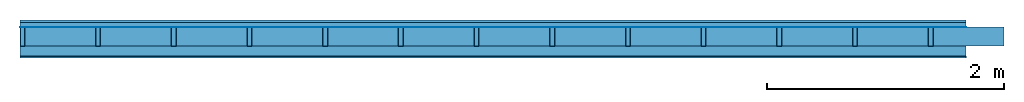
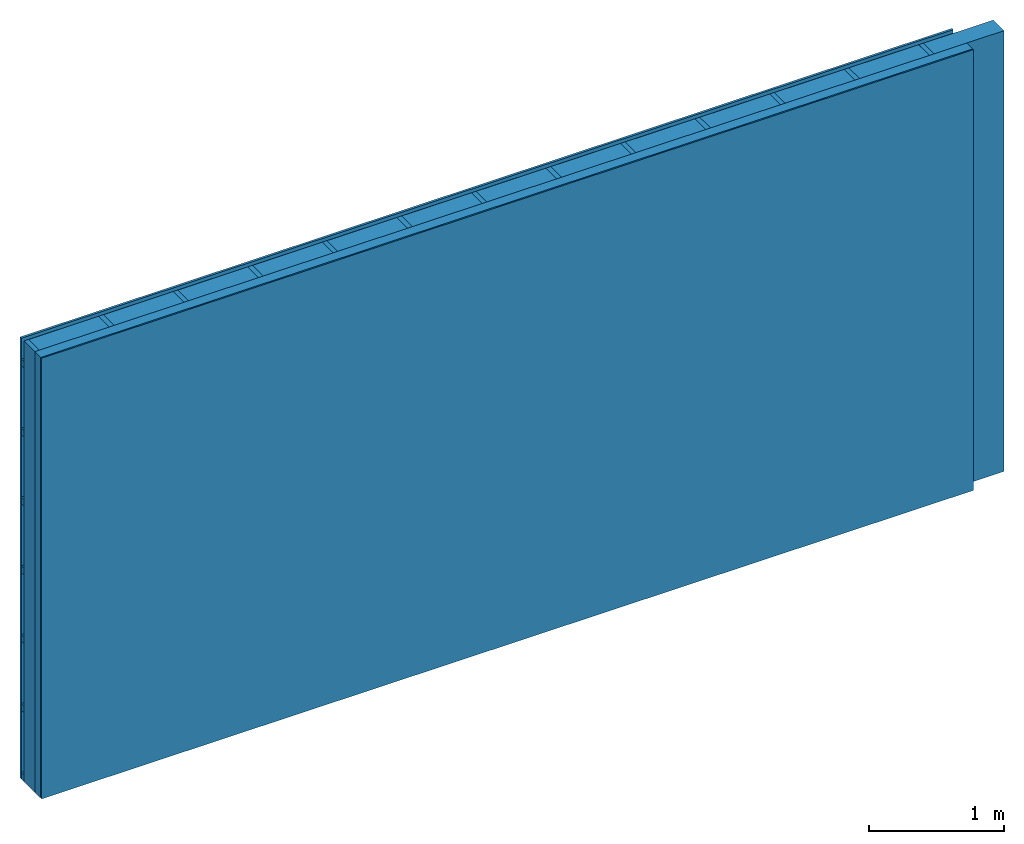
# One storey: 4 plates, 3 members, 1 element without a shape of its own.
"""IFC4 building model written with IfcOpenShell, lengths in metres."""

import ifcopenshell
import ifcopenshell.guid

model = None  # the IFC model being written
_history = None  # IfcOwnerHistory: only IFC2X3 demands one
_inside = {}  # id of a spatial element -> (the spatial element, [elements in it])
_under = {}  # id of a project, library or spatial element -> (it, [spatial elements below it])
_declared = {}  # id of a project -> (the project, [libraries it declares])
_typed = {}  # id of a type object -> (the type object, [elements of that type])
_made_of = {}  # id of a material, layer set ... -> (it, [elements and type objects made of it])


def new_model(schema):
    """Start an empty IFC model of exactly this schema.

    Asked for "IFC4X3", IfcOpenShell would pick the latest addendum, in which some entities
    have other attributes; the version numbers below select the first issue.
    IFC2X3 requires an IfcOwnerHistory on every rooted entity: one is made here for all.
    """
    global model, _history
    if schema == "IFC4X3":
        model = ifcopenshell.file(schema_version=(4, 3, 0, 0))
    else:
        model = ifcopenshell.file(schema=schema)
    _inside.clear()
    _under.clear()
    _declared.clear()
    _typed.clear()
    _made_of.clear()
    _history = None
    if model.schema == "IFC2X3":
        org = make("IfcOrganization", Name="unknown")
        user = make(
            "IfcPersonAndOrganization",
            ThePerson=make("IfcPerson", FamilyName="unknown"),
            TheOrganization=org,
        )
        app = make(
            "IfcApplication",
            ApplicationDeveloper=org,
            Version="unknown",
            ApplicationFullName="unknown",
            ApplicationIdentifier="unknown",
        )
        _history = make(
            "IfcOwnerHistory",
            OwningUser=user,
            OwningApplication=app,
            ChangeAction="ADDED",
            CreationDate=0,
        )
    return model


def make(cls, **values):
    """One entity of the class cls with the attributes given. An attribute that is None is left unset."""
    return model.create_entity(
        cls, **{name: value for name, value in values.items() if value is not None}
    )


def rooted(cls, **values):
    """An entity with a GlobalId (a new one), such as an element, a storey or a relation."""
    return make(cls, GlobalId=ifcopenshell.guid.new(), OwnerHistory=_history, **values)


def si_unit(unit_type, name, prefix=None):
    """IfcSIUnit, for example si_unit("LENGTHUNIT", "METRE", prefix="MILLI")."""
    return make("IfcSIUnit", UnitType=unit_type, Prefix=prefix, Name=name)


def derived_unit(unit_type, elements):
    """IfcDerivedUnit: a product of units, each with its exponent."""
    return make(
        "IfcDerivedUnit",
        Elements=[
            make("IfcDerivedUnitElement", Unit=unit, Exponent=power)
            for unit, power in elements
        ],
        UnitType=unit_type,
    )


def assignment(units):
    """IfcUnitAssignment: the units of a project."""
    return None if units is None else make("IfcUnitAssignment", Units=units)


def point(xyz):
    """IfcCartesianPoint."""
    return None if xyz is None else make("IfcCartesianPoint", Coordinates=xyz)


def direction(xyz):
    """IfcDirection."""
    return None if xyz is None else make("IfcDirection", DirectionRatios=xyz)


def frame(location, z_axis=None, x_axis=None):
    """IfcAxis2Placement3D, a coordinate frame: its origin and axes. An axis left out is left unset."""
    return make(
        "IfcAxis2Placement3D",
        Location=point(location),
        Axis=direction(z_axis),
        RefDirection=direction(x_axis),
    )


def frame_2d(location, x_axis=None):
    """IfcAxis2Placement2D, a coordinate frame in the plane: its origin and x axis."""
    return make(
        "IfcAxis2Placement2D", Location=point(location), RefDirection=direction(x_axis)
    )


def origin():
    """The frame at (0, 0, 0) with its axes left unset."""
    return frame((0.0, 0.0, 0.0))


def origin_with_axes():
    """The frame at (0, 0, 0) with the z axis (0, 0, 1) and the x axis (1, 0, 0) written out."""
    return frame((0.0, 0.0, 0.0), z_axis=(0.0, 0.0, 1.0), x_axis=(1.0, 0.0, 0.0))


def place(relative_to, where):
    """IfcLocalPlacement: puts the frame where relative to a parent placement (None: the world)."""
    return make(
        "IfcLocalPlacement", PlacementRelTo=relative_to, RelativePlacement=where
    )


def context(
    kind, dimensions, precision=None, world=None, true_north=None, identifier=None
):
    """IfcGeometricRepresentationContext, for example the 3D "Model" context."""
    return make(
        "IfcGeometricRepresentationContext",
        ContextIdentifier=identifier,
        ContextType=kind,
        CoordinateSpaceDimension=dimensions,
        Precision=precision,
        WorldCoordinateSystem=world,
        TrueNorth=true_north,
    )


def project(units=None, contexts=None):
    """IfcProject with its units and contexts."""
    return rooted(
        "IfcProject",
        Name="project",
        RepresentationContexts=contexts,
        UnitsInContext=assignment(units),
    )


def spatial(cls, under=None, at=None, **own):
    """A site, building, storey or space (cls), placed at a placement, below another one or the project."""
    s = rooted(cls, ObjectPlacement=at, **own)
    if under is not None:
        _under.setdefault(under.id(), (under, []))[1].append(s)
    return s


def profile(cls, at=None, kind="AREA", **sizes):
    """A parametric profile (cls). Its sizes go by their IFC names, for example OverallWidth=200.0."""
    return make(cls, ProfileType=kind, Position=at, **sizes)


def rectangle(**sizes):
    """IfcRectangleProfileDef."""
    return profile("IfcRectangleProfileDef", **sizes)


def extrude(swept, where, along, depth):
    """IfcExtrudedAreaSolid: the profile swept, set in the frame where, extruded along a direction by depth."""
    return make(
        "IfcExtrudedAreaSolid",
        SweptArea=swept,
        Position=where,
        ExtrudedDirection=direction(along),
        Depth=depth,
    )


def shape(context_of_items, identifier, shape_type, items):
    """IfcShapeRepresentation: the items that make up one representation, for example the "Body"."""
    return make(
        "IfcShapeRepresentation",
        ContextOfItems=context_of_items,
        RepresentationIdentifier=identifier,
        RepresentationType=shape_type,
        Items=items,
    )


def material(Name=None, Category=None):
    """IfcMaterial."""
    return make("IfcMaterial", Name=Name, Category=Category)


def layer(
    of_material, thickness, ventilated=None, Name=None, Category=None, Priority=None
):
    """IfcMaterialLayer: one layer of a wall or slab, of a material (None: an air gap)."""
    return make(
        "IfcMaterialLayer",
        Material=of_material,
        LayerThickness=thickness,
        IsVentilated=ventilated,
        Name=Name,
        Category=Category,
        Priority=Priority,
    )


def layer_set(layers, Name=None):
    """IfcMaterialLayerSet."""
    return make("IfcMaterialLayerSet", MaterialLayers=layers, LayerSetName=Name)


def made_of(thing, what):
    """Note that an element or type object is made of a material, layer set ...; save() writes the relation."""
    if what is not None:
        _made_of.setdefault(what.id(), (what, []))[1].append(thing)
    return thing


def type_object(cls, material=None, **own):
    """A type object (cls), such as IfcWallType, which elements share."""
    return made_of(rooted(cls, **own), material)


def element(
    cls,
    number,
    at=None,
    inside=None,
    cuts=None,
    type_object=None,
    material=None,
    context=None,
    identifier="Body",
    shape_type=None,
    held_by="IfcProductDefinitionShape",
    body=None,
    shapes=None,
    **own,
):
    """One element of the class cls, such as IfcWall. Its Tag is "e" and its number.

    at: its placement. inside: the storey or other place that contains it. cuts: it is an
    opening in that element (IfcRelVoidsElement). A single representation is given by context,
    identifier, shape_type and body (its items); several are given by shapes. held_by: the class
    of the entity that holds the representations. save() writes the other relations.
    """
    e = rooted(cls, Tag="e%d" % number, ObjectPlacement=at, **own)
    if body is not None:
        shapes = [shape(context, identifier, shape_type, body)]
    if shapes is not None:
        e.Representation = make(held_by, Representations=shapes)
    if inside is not None:
        _inside.setdefault(inside.id(), (inside, []))[1].append(e)
    if cuts is not None:
        rooted(
            "IfcRelVoidsElement", RelatingBuildingElement=cuts, RelatedOpeningElement=e
        )
    if type_object is not None:
        _typed.setdefault(type_object.id(), (type_object, []))[1].append(e)
    return made_of(e, material)


def aggregate(whole, parts):
    """IfcRelAggregates: a whole, such as a stair, and the parts it consists of."""
    return rooted("IfcRelAggregates", RelatingObject=whole, RelatedObjects=parts)


def save(model, path):
    """Write the relations noted so far, then the file.

    IfcRelAggregates (storeys below a building ...), IfcRelContainedInSpatialStructure (elements
    in a storey), IfcRelDefinesByType, IfcRelAssociatesMaterial and IfcRelDeclares: one each for
    every whole, place, type object, material and project.
    """
    for whole, parts in _under.values():
        aggregate(whole, parts)
    for where, things in _inside.values():
        rooted(
            "IfcRelContainedInSpatialStructure",
            RelatedElements=things,
            RelatingStructure=where,
        )
    for kind, things in _typed.values():
        rooted("IfcRelDefinesByType", RelatedObjects=things, RelatingType=kind)
    for what, things in _made_of.values():
        rooted("IfcRelAssociatesMaterial", RelatedObjects=things, RelatingMaterial=what)
    for by, libraries in _declared.values():
        rooted("IfcRelDeclares", RelatingContext=by, RelatedDefinitions=libraries)
    model.write(path)


model = new_model("IFC4")

# Units and contexts
plan_context = context("Plan", 3, precision=1e-05, world=origin(), true_north=direction((0.0, 1.0)))
model_context = context("Model", 3, precision=1e-05, world=origin(), true_north=direction((0.0, 1.0)))
ifc_project = project(units=[si_unit("LENGTHUNIT", "METRE"), derived_unit("SOUNDPRESSUREUNIT", [(si_unit("PRESSUREUNIT", "PASCAL", prefix="MICRO"), 0)]), si_unit("ENERGYUNIT", "JOULE", prefix="MEGA"), si_unit("MASSUNIT", "GRAM", prefix="KILO"), derived_unit("THERMALTRANSMITTANCEUNIT", [(si_unit("POWERUNIT", "WATT"), 1), (si_unit("AREAUNIT", "SQUARE_METRE"), -1), (si_unit("THERMODYNAMICTEMPERATUREUNIT", "KELVIN"), -1)]), derived_unit("AREADENSITYUNIT", [(si_unit("MASSUNIT", "GRAM", prefix="KILO"), 1), (si_unit("AREAUNIT", "SQUARE_METRE"), -1)]), derived_unit("USERDEFINED", [(si_unit("ENERGYUNIT", "JOULE", prefix="MEGA"), 1), (si_unit("AREAUNIT", "SQUARE_METRE"), -1)])], contexts=[plan_context, model_context])

# Site, building, storey
site = spatial("IfcSite", under=ifc_project)
building_placement = place(None, origin())
building = spatial("IfcBuilding", under=site, at=building_placement)
storey_placement = place(building_placement, origin())
storey = spatial("IfcBuildingStorey", under=building, at=storey_placement)

# Wall, members, plates
ifc_material_1 = material(Name="Wood cladding horizontal, closed")
ifc_layer_1 = layer(ifc_material_1, 0.02, Name="Cover 1st layer")
ifc_layer_2 = layer(None, 0.04, Name="Battens / profiles (ventilation)")
ifc_material_2 = material(Name="Vapor-permeable water barrier", Category="09.006")
ifc_layer_3 = layer(ifc_material_2, 0.0005, Name="outside 1st layer")
ifc_material_3 = material(Name="of the art")
ifc_layer_4 = layer(ifc_material_3, 0.0, Name="Bond")
ifc_layer_5 = layer(None, 0.16, Name="Support")
ifc_layer_6 = layer(ifc_material_3, 0.0, Name="Bond")
ifc_material_4 = material(Name="Solid timber panel")
ifc_layer_7 = layer(ifc_material_4, 0.087, Name="1st layer")
ifc_material_5 = material(Name="Plasterboard type A", Category="03.008")
ifc_layer_8 = layer(ifc_material_5, 0.0125, Name="Covering 1st layer")
ifc_material_6 = material(Name="joints", Category="04.017")
ifc_layer_9 = layer(ifc_material_6, 0.0, Name="Surface")
ifc_layer_set = layer_set([ifc_layer_1, ifc_layer_2, ifc_layer_3, ifc_layer_4, ifc_layer_5, ifc_layer_6, ifc_layer_7, ifc_layer_8, ifc_layer_9])
wall_type = type_object("IfcWallType", Name="D0984", PredefinedType="NOTDEFINED", material=ifc_layer_set)
wall_placement = place(None, frame((0.0, 0.0, 0.0), z_axis=(0.0, -1.0, 0.0), x_axis=(1.0, 0.0, 0.0)))
wall = element("IfcWall", 1, at=wall_placement, inside=storey, type_object=wall_type, material=ifc_layer_set, Name="Wall #1")
ifc_material_7 = material()
member_1_placement = place(wall_placement, origin())
member_1 = element("IfcMember", 2, at=member_1_placement, material=ifc_material_7, Name="Battens / profiles (ventilation)", context=plan_context, shape_type="SweptSolid", body=[
    extrude(rectangle(XDim=0.06, YDim=0.04, at=frame_2d((0.03, 0.02), x_axis=(1.0, 0.0))), frame((0.0, 0.0, 0.02), z_axis=(1.0, 0.0, 0.0), x_axis=(0.0, 1.0, 0.0)), (0.0, 0.0, 1.0), 8.0),
    extrude(rectangle(XDim=0.06, YDim=0.04, at=frame_2d((0.03, 0.02), x_axis=(1.0, 0.0))), frame((0.0, 0.625, 0.02), z_axis=(1.0, 0.0, 0.0), x_axis=(0.0, 1.0, 0.0)), (0.0, 0.0, 1.0), 8.0),
    extrude(rectangle(XDim=0.06, YDim=0.04, at=frame_2d((0.03, 0.02), x_axis=(1.0, 0.0))), frame((0.0, 1.25, 0.02), z_axis=(1.0, 0.0, 0.0), x_axis=(0.0, 1.0, 0.0)), (0.0, 0.0, 1.0), 8.0),
    extrude(rectangle(XDim=0.06, YDim=0.04, at=frame_2d((0.03, 0.02), x_axis=(1.0, 0.0))), frame((0.0, 1.875, 0.02), z_axis=(1.0, 0.0, 0.0), x_axis=(0.0, 1.0, 0.0)), (0.0, 0.0, 1.0), 8.0),
    extrude(rectangle(XDim=0.06, YDim=0.04, at=frame_2d((0.03, 0.02), x_axis=(1.0, 0.0))), frame((0.0, 2.5, 0.02), z_axis=(1.0, 0.0, 0.0), x_axis=(0.0, 1.0, 0.0)), (0.0, 0.0, 1.0), 8.0),
    extrude(rectangle(XDim=0.06, YDim=0.04, at=frame_2d((0.03, 0.02), x_axis=(1.0, 0.0))), frame((0.0, 3.125, 0.02), z_axis=(1.0, 0.0, 0.0), x_axis=(0.0, 1.0, 0.0)), (0.0, 0.0, 1.0), 8.0),
    extrude(rectangle(XDim=0.06, YDim=0.04, at=frame_2d((0.03, 0.02), x_axis=(1.0, 0.0))), frame((0.0, 3.75, 0.02), z_axis=(1.0, 0.0, 0.0), x_axis=(0.0, 1.0, 0.0)), (0.0, 0.0, 1.0), 8.0),
])
ifc_material_8 = material()
member_2_placement = place(wall_placement, origin())
member_2 = element("IfcMember", 3, at=member_2_placement, material=ifc_material_8, Name="Support", context=plan_context, shape_type="SweptSolid", body=[
    extrude(rectangle(XDim=0.04, YDim=0.16, at=frame_2d((0.02, 0.08), x_axis=(1.0, 0.0))), frame((0.0, 4.0, 0.0605), z_axis=(0.0, -1.0, 0.0), x_axis=(1.0, 0.0, 0.0)), (0.0, 0.0, 1.0), 4.0),
    extrude(rectangle(XDim=0.04, YDim=0.16, at=frame_2d((0.02, 0.08), x_axis=(1.0, 0.0))), frame((0.64, 4.0, 0.0605), z_axis=(0.0, -1.0, 0.0), x_axis=(1.0, 0.0, 0.0)), (0.0, 0.0, 1.0), 4.0),
    extrude(rectangle(XDim=0.04, YDim=0.16, at=frame_2d((0.02, 0.08), x_axis=(1.0, 0.0))), frame((1.28, 4.0, 0.0605), z_axis=(0.0, -1.0, 0.0), x_axis=(1.0, 0.0, 0.0)), (0.0, 0.0, 1.0), 4.0),
    extrude(rectangle(XDim=0.04, YDim=0.16, at=frame_2d((0.02, 0.08), x_axis=(1.0, 0.0))), frame((1.92, 4.0, 0.0605), z_axis=(0.0, -1.0, 0.0), x_axis=(1.0, 0.0, 0.0)), (0.0, 0.0, 1.0), 4.0),
    extrude(rectangle(XDim=0.04, YDim=0.16, at=frame_2d((0.02, 0.08), x_axis=(1.0, 0.0))), frame((2.56, 4.0, 0.0605), z_axis=(0.0, -1.0, 0.0), x_axis=(1.0, 0.0, 0.0)), (0.0, 0.0, 1.0), 4.0),
    extrude(rectangle(XDim=0.04, YDim=0.16, at=frame_2d((0.02, 0.08), x_axis=(1.0, 0.0))), frame((3.2, 4.0, 0.0605), z_axis=(0.0, -1.0, 0.0), x_axis=(1.0, 0.0, 0.0)), (0.0, 0.0, 1.0), 4.0),
    extrude(rectangle(XDim=0.04, YDim=0.16, at=frame_2d((0.02, 0.08), x_axis=(1.0, 0.0))), frame((3.84, 4.0, 0.0605), z_axis=(0.0, -1.0, 0.0), x_axis=(1.0, 0.0, 0.0)), (0.0, 0.0, 1.0), 4.0),
    extrude(rectangle(XDim=0.04, YDim=0.16, at=frame_2d((0.02, 0.08), x_axis=(1.0, 0.0))), frame((4.48, 4.0, 0.0605), z_axis=(0.0, -1.0, 0.0), x_axis=(1.0, 0.0, 0.0)), (0.0, 0.0, 1.0), 4.0),
    extrude(rectangle(XDim=0.04, YDim=0.16, at=frame_2d((0.02, 0.08), x_axis=(1.0, 0.0))), frame((5.12, 4.0, 0.0605), z_axis=(0.0, -1.0, 0.0), x_axis=(1.0, 0.0, 0.0)), (0.0, 0.0, 1.0), 4.0),
    extrude(rectangle(XDim=0.04, YDim=0.16, at=frame_2d((0.02, 0.08), x_axis=(1.0, 0.0))), frame((5.76, 4.0, 0.0605), z_axis=(0.0, -1.0, 0.0), x_axis=(1.0, 0.0, 0.0)), (0.0, 0.0, 1.0), 4.0),
    extrude(rectangle(XDim=0.04, YDim=0.16, at=frame_2d((0.02, 0.08), x_axis=(1.0, 0.0))), frame((6.4, 4.0, 0.0605), z_axis=(0.0, -1.0, 0.0), x_axis=(1.0, 0.0, 0.0)), (0.0, 0.0, 1.0), 4.0),
    extrude(rectangle(XDim=0.04, YDim=0.16, at=frame_2d((0.02, 0.08), x_axis=(1.0, 0.0))), frame((7.04, 4.0, 0.0605), z_axis=(0.0, -1.0, 0.0), x_axis=(1.0, 0.0, 0.0)), (0.0, 0.0, 1.0), 4.0),
    extrude(rectangle(XDim=0.04, YDim=0.16, at=frame_2d((0.02, 0.08), x_axis=(1.0, 0.0))), frame((7.68, 4.0, 0.0605), z_axis=(0.0, -1.0, 0.0), x_axis=(1.0, 0.0, 0.0)), (0.0, 0.0, 1.0), 4.0),
])
ifc_material_9 = material(Name="Mineral wool")
member_3_placement = place(wall_placement, origin())
member_3 = element("IfcMember", 4, at=member_3_placement, material=ifc_material_9, Name="Cavity", context=plan_context, shape_type="SweptSolid", body=[
    extrude(rectangle(XDim=0.6, YDim=0.16, at=frame_2d((0.3, 0.08), x_axis=(1.0, 0.0))), frame((0.04, 4.0, 0.0605), z_axis=(0.0, -1.0, 0.0), x_axis=(1.0, 0.0, 0.0)), (0.0, 0.0, 1.0), 4.0),
    extrude(rectangle(XDim=0.6, YDim=0.16, at=frame_2d((0.3, 0.08), x_axis=(1.0, 0.0))), frame((0.68, 4.0, 0.0605), z_axis=(0.0, -1.0, 0.0), x_axis=(1.0, 0.0, 0.0)), (0.0, 0.0, 1.0), 4.0),
    extrude(rectangle(XDim=0.6, YDim=0.16, at=frame_2d((0.3, 0.08), x_axis=(1.0, 0.0))), frame((1.32, 4.0, 0.0605), z_axis=(0.0, -1.0, 0.0), x_axis=(1.0, 0.0, 0.0)), (0.0, 0.0, 1.0), 4.0),
    extrude(rectangle(XDim=0.6, YDim=0.16, at=frame_2d((0.3, 0.08), x_axis=(1.0, 0.0))), frame((1.96, 4.0, 0.0605), z_axis=(0.0, -1.0, 0.0), x_axis=(1.0, 0.0, 0.0)), (0.0, 0.0, 1.0), 4.0),
    extrude(rectangle(XDim=0.6, YDim=0.16, at=frame_2d((0.3, 0.08), x_axis=(1.0, 0.0))), frame((2.6, 4.0, 0.0605), z_axis=(0.0, -1.0, 0.0), x_axis=(1.0, 0.0, 0.0)), (0.0, 0.0, 1.0), 4.0),
    extrude(rectangle(XDim=0.6, YDim=0.16, at=frame_2d((0.3, 0.08), x_axis=(1.0, 0.0))), frame((3.24, 4.0, 0.0605), z_axis=(0.0, -1.0, 0.0), x_axis=(1.0, 0.0, 0.0)), (0.0, 0.0, 1.0), 4.0),
    extrude(rectangle(XDim=0.6, YDim=0.16, at=frame_2d((0.3, 0.08), x_axis=(1.0, 0.0))), frame((3.88, 4.0, 0.0605), z_axis=(0.0, -1.0, 0.0), x_axis=(1.0, 0.0, 0.0)), (0.0, 0.0, 1.0), 4.0),
    extrude(rectangle(XDim=0.6, YDim=0.16, at=frame_2d((0.3, 0.08), x_axis=(1.0, 0.0))), frame((4.52, 4.0, 0.0605), z_axis=(0.0, -1.0, 0.0), x_axis=(1.0, 0.0, 0.0)), (0.0, 0.0, 1.0), 4.0),
    extrude(rectangle(XDim=0.6, YDim=0.16, at=frame_2d((0.3, 0.08), x_axis=(1.0, 0.0))), frame((5.16, 4.0, 0.0605), z_axis=(0.0, -1.0, 0.0), x_axis=(1.0, 0.0, 0.0)), (0.0, 0.0, 1.0), 4.0),
    extrude(rectangle(XDim=0.6, YDim=0.16, at=frame_2d((0.3, 0.08), x_axis=(1.0, 0.0))), frame((5.8, 4.0, 0.0605), z_axis=(0.0, -1.0, 0.0), x_axis=(1.0, 0.0, 0.0)), (0.0, 0.0, 1.0), 4.0),
    extrude(rectangle(XDim=0.6, YDim=0.16, at=frame_2d((0.3, 0.08), x_axis=(1.0, 0.0))), frame((6.44, 4.0, 0.0605), z_axis=(0.0, -1.0, 0.0), x_axis=(1.0, 0.0, 0.0)), (0.0, 0.0, 1.0), 4.0),
    extrude(rectangle(XDim=0.6, YDim=0.16, at=frame_2d((0.3, 0.08), x_axis=(1.0, 0.0))), frame((7.08, 4.0, 0.0605), z_axis=(0.0, -1.0, 0.0), x_axis=(1.0, 0.0, 0.0)), (0.0, 0.0, 1.0), 4.0),
    extrude(rectangle(XDim=0.6, YDim=0.16, at=frame_2d((0.3, 0.08), x_axis=(1.0, 0.0))), frame((7.72, 4.0, 0.0605), z_axis=(0.0, -1.0, 0.0), x_axis=(1.0, 0.0, 0.0)), (0.0, 0.0, 1.0), 4.0),
])
plate_1_placement = place(wall_placement, origin())
plate_1 = element("IfcPlate", 5, at=plate_1_placement, material=ifc_material_1, Name="Cover 1st layer", context=plan_context, shape_type="SweptSolid", body=[
    extrude(rectangle(XDim=8.0, YDim=4.0, at=frame_2d((4.0, 2.0), x_axis=(1.0, 0.0))), origin_with_axes(), (0.0, 0.0, 1.0), 0.02),
])
plate_2_placement = place(wall_placement, origin())
plate_2 = element("IfcPlate", 6, at=plate_2_placement, material=ifc_material_2, Name="outside 1st layer", context=plan_context, shape_type="SweptSolid", body=[
    extrude(rectangle(XDim=8.0, YDim=4.0, at=frame_2d((4.0, 2.0), x_axis=(1.0, 0.0))), frame((0.0, 0.0, 0.06), z_axis=(0.0, 0.0, 1.0), x_axis=(1.0, 0.0, 0.0)), (0.0, 0.0, 1.0), 0.0005),
])
plate_3_placement = place(wall_placement, origin())
plate_3 = element("IfcPlate", 7, at=plate_3_placement, material=ifc_material_4, Name="1st layer", context=plan_context, shape_type="SweptSolid", body=[
    extrude(rectangle(XDim=8.0, YDim=4.0, at=frame_2d((4.0, 2.0), x_axis=(1.0, 0.0))), frame((0.0, 0.0, 0.2205), z_axis=(0.0, 0.0, 1.0), x_axis=(1.0, 0.0, 0.0)), (0.0, 0.0, 1.0), 0.087),
])
plate_4_placement = place(wall_placement, origin())
plate_4 = element("IfcPlate", 8, at=plate_4_placement, material=ifc_material_5, Name="Covering 1st layer", context=plan_context, shape_type="SweptSolid", body=[
    extrude(rectangle(XDim=8.0, YDim=4.0, at=frame_2d((4.0, 2.0), x_axis=(1.0, 0.0))), frame((0.0, 0.0, 0.3075), z_axis=(0.0, 0.0, 1.0), x_axis=(1.0, 0.0, 0.0)), (0.0, 0.0, 1.0), 0.0125),
])
aggregate(wall, [plate_1, member_1, plate_2, member_2, member_3, plate_3, plate_4])

save(model, "model.ifc")
